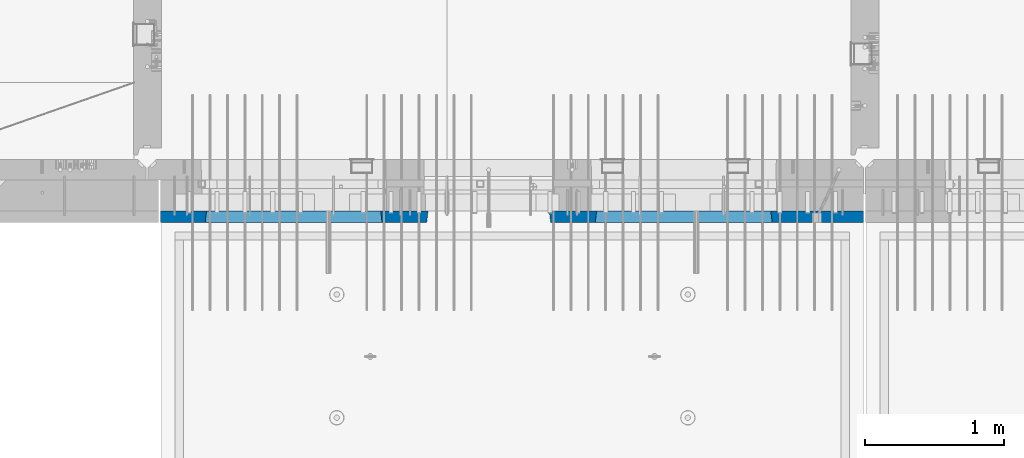
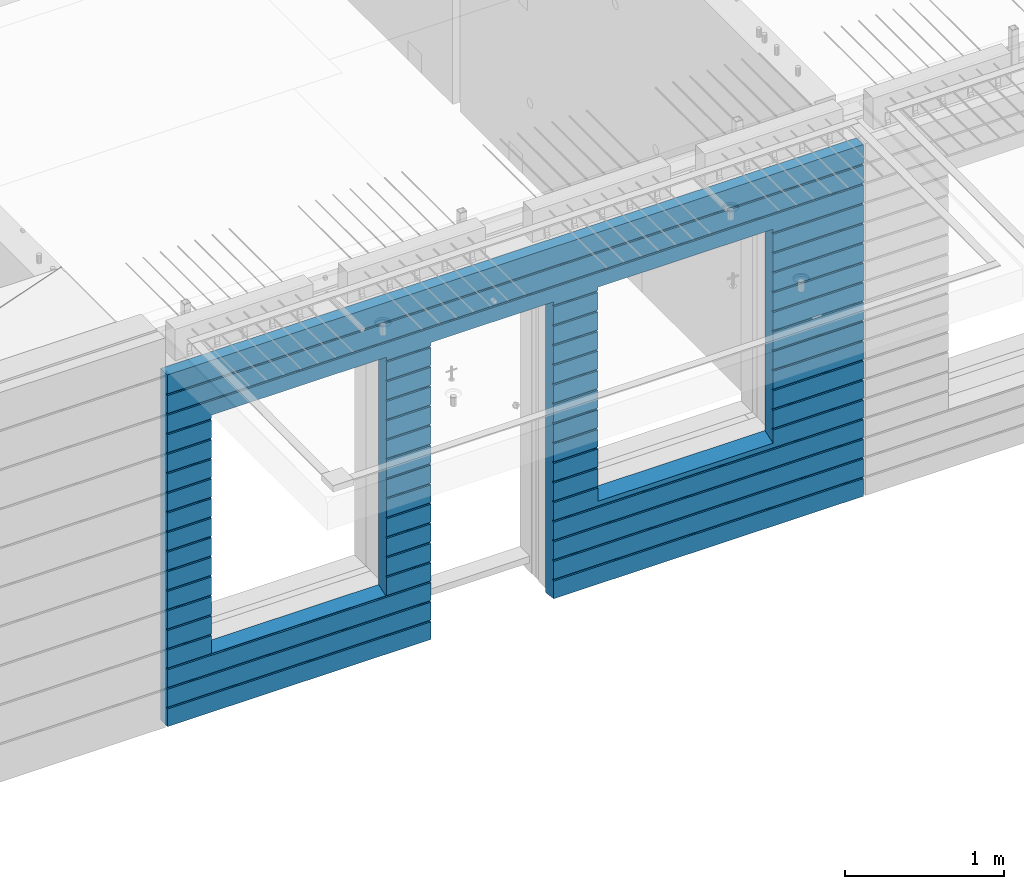
# One storey, part 231 of 352: 1 wall, 1 element without a shape of its own.
"""IFC2X3 building model written with IfcOpenShell, lengths in millimetres."""

from ifc_helpers import new_model, si_unit, frame, origin_with_axes, place, context, subcontext, project, spatial, faceted_brep, material, type_object, element, aggregate, save


model = new_model("IFC2X3")

# Units and contexts
model_context = context("Model", 3, precision=1e-05, world=origin_with_axes())
body_context = subcontext(model_context, "Body", "Model", "MODEL_VIEW")
ifc_project = project(units=[si_unit("LENGTHUNIT", "METRE", prefix="MILLI"), si_unit("AREAUNIT", "SQUARE_METRE"), si_unit("VOLUMEUNIT", "CUBIC_METRE"), si_unit("MASSUNIT", "GRAM", prefix="KILO"), si_unit("TIMEUNIT", "SECOND"), si_unit("PLANEANGLEUNIT", "RADIAN"), si_unit("SOLIDANGLEUNIT", "STERADIAN"), si_unit("THERMODYNAMICTEMPERATUREUNIT", "DEGREE_CELSIUS"), si_unit("LUMINOUSINTENSITYUNIT", "LUMEN")], contexts=[model_context])

# Site, building, storey
site_placement = place(None, origin_with_axes())
site = spatial("IfcSite", under=ifc_project, at=site_placement, CompositionType="ELEMENT")
building_placement = place(site_placement, origin_with_axes())
building = spatial("IfcBuilding", under=site, at=building_placement, CompositionType="ELEMENT")
storey_placement = place(building_placement, origin_with_axes())
storey = spatial("IfcBuildingStorey", under=building, at=storey_placement, Name="6", CompositionType="ELEMENT", Elevation=0.0)

# Assembly, wall
assembly_placement = place(storey_placement, origin_with_axes())
assembly = element("IfcElementAssembly", 1, at=assembly_placement, inside=storey, AssemblyPlace="NOTDEFINED", PredefinedType="REINFORCEMENT_UNIT")
ifc_material = material(Name="CONCRETE/C30/37")
wall_type = type_object("IfcWallType", PredefinedType="NOTDEFINED")
wall_placement = place(assembly_placement, frame((21810.0, 7587.5, 98102.5), z_axis=(0.0, 0.0, 1.0), x_axis=(-1.0, 3.00000001838171e-08, 0.0)))
wall = element("IfcWall", 2, at=wall_placement, type_object=wall_type, material=ifc_material, context=body_context, shape_type="Brep", body=[
    faceted_brep([(3465.15088791894, 41.2121213860573, -911.742424344746), (3464.99937278789, 42.5, -912.5), (3464.99937278789, 42.5, -912.000000055254), (4734.84785765683, 41.2121213860573, -911.742424344746), (4734.99937278789, 42.5, -912.5), (4734.99937278789, 42.5, -912.000000055254), (10.0, 42.5, -1347.5), (10.0, 42.5, -1212.00000005524), (2254.99845837354, 42.5, -1212.00000005524), (2254.99845837354, 42.5, -1347.5), (10.0, 32.4999992501662, -1210.00000000079), (2256.17512512844, 32.4999992501662, -1210.00000000079), (10.0000007500639, 32.499999249937, -1200.00000000079), (2256.17512514468, 32.4999991121731, -1199.99999959956), (10.0, 42.5, -1198.00000011075), (2254.99845837354, 42.5, -1198.00000011075), (10.0, 42.5, -1062.00000005522), (2254.99845837354, 42.5, -1062.00000005522), (10.0, 32.4999992506964, -1060.00000000079), (2256.17512512838, 32.4999992506964, -1060.00000000079), (10.0000007500657, 32.499999249937, -1050.00000000079), (2256.17512514461, 32.499999112697, -1049.99999959956), (10.0, 42.5, -1048.00000011074), (2254.99845837354, 42.5, -1048.00000011074), (10.0, 42.5, -912.000000055254), (2254.99845837354, 42.5, -912.000000055254), (10.0, 32.4999992512312, -910.000000000815), (2256.17512512832, 32.4999992512312, -910.000000000815), (10.0000007500657, 32.499999249937, -900.000000000786), (2256.17512514455, 32.4999991132318, -899.99999959959), (10.0, 42.5, -898.000000110769), (2254.99845837354, 42.5, -898.000000110769), (10.0, 42.5, -762.000000055225), (2254.99845837354, 42.5, -762.000000055225), (10.0, 32.4999992517696, -760.000000000771), (2256.17512512825, 32.4999992517696, -760.000000000771), (10.0000007500657, 32.499999249937, -750.000000000786), (2256.17512514449, 32.4999991137747, -749.999999599546), (10.0, 42.5, -748.00000011074), (2254.99845837354, 42.5, -748.00000011074), (675.00013572734, 42.5, 927.5), (1925.00013572734, 42.5, 927.5), (1935.00013572734, 42.5, 927.5), (1925.00013572734, -42.5, 932.5), (675.00013572734, -42.5, 932.5), (665.00013572734, 42.5, 927.5), (665.00013572734, 42.5, -712.5), (675.00013572734, -42.5, -662.5), (1925.00013572734, -42.5, -662.5), (1935.00013572734, 42.5, -712.5), (1925.00013572734, -42.5, 927.5), (1935.00013572734, 42.5, 901.999999889245), (1933.82366503463, 32.4999991119776, 900.000000400425), (1933.82366505087, 32.4999992499834, 889.9999999992), (1935.00013572734, 42.5, 887.999999944761), (1935.00013572734, 42.5, 751.999999889245), (1933.82366503463, 32.4999991119885, 750.000000400425), (1933.82366505087, 32.4999992499925, 739.9999999992), (1935.00013572734, 42.5, 737.999999944761), (1935.00013572734, 42.5, 601.99999988926), (1933.82366503463, 32.4999991120112, 600.00000040044), (1933.82366505087, 32.4999992500152, 589.999999999214), (1935.00013572734, 42.5, 587.999999944775), (1935.00013572734, 42.5, 451.999999889245), (1933.82366503464, 32.4999991120167, 450.000000400425), (1933.82366505087, 32.4999992500216, 439.9999999992), (1935.00013572734, 42.5, 437.999999944761), (1935.00013572734, 42.5, 301.999999889245), (1933.82366503464, 32.4999991120312, 300.000000400425), (1933.82366505087, 32.4999992500352, 289.9999999992), (1935.00013572734, 42.5, 287.999999944761), (1935.00013572734, 42.5, 151.999999889245), (1933.82366503464, 32.4999991120421, 150.000000400425), (1933.82366505088, 32.499999250047, 139.9999999992), (1935.00013572734, 42.5, 137.999999944761), (1935.00013572734, 42.5, 1.99999988923082), (1933.82366503515, 32.4999991164286, 4.00410499423742e-07), (1933.82366505139, 32.4999992544263, -10.0000000008149), (1935.00013572734, 42.5, -12.0000000552536), (1935.00013572734, 42.5, -148.000000110755), (1933.82366503509, 32.4999991158993, -149.99999959956), (1933.82366505132, 32.4999992538915, -160.000000000786), (1935.00013572734, 42.5, -162.000000055239), (1935.00013572734, 42.5, -298.000000110755), (1933.82366503503, 32.49999911536, -299.999999599575), (1933.82366505126, 32.4999992533594, -310.0000000008), (1935.00013572734, 42.5, -312.000000055239), (1935.00013572734, 42.5, -448.00000011074), (1933.82366503496, 32.4999991148343, -449.99999959956), (1933.8236650512, 32.4999992528337, -460.000000000786), (1935.00013572734, 42.5, -462.000000055225), (1935.00013572734, 42.5, -598.000000110755), (1933.8236650349, 32.499999114295, -599.999999599575), (1933.82366505114, 32.4999992522935, -610.0000000008), (1935.00013572734, 42.5, -612.000000055239), (2256.1751251447, 32.4999991119776, 900.000000400425), (2256.17512512846, 32.4999992499834, 889.9999999992), (2254.99845837354, 42.5, 887.999999944761), (2254.99845837354, 42.5, 751.999999889245), (2256.17512514469, 32.4999991119885, 750.000000400425), (2256.17512512846, 32.4999992499925, 739.9999999992), (2254.99845837354, 42.5, 737.999999944761), (2254.99845837354, 42.5, 601.99999988926), (2256.17512514469, 32.4999991120112, 600.00000040044), (2256.17512512846, 32.4999992500152, 589.999999999214), (2254.99845837354, 42.5, 587.999999944775), (2254.99845837354, 42.5, 451.999999889245), (2256.17512514469, 32.4999991120167, 450.000000400425), (2256.17512512846, 32.4999992500216, 439.9999999992), (2254.99845837354, 42.5, 437.999999944761), (2254.99845837354, 42.5, 301.999999889245), (2256.17512514469, 32.4999991120312, 300.000000400425), (2256.17512512846, 32.4999992500352, 289.9999999992), (2254.99845837354, 42.5, 287.999999944761), (2254.99845837354, 42.5, 151.999999889245), (2256.17512514469, 32.4999991120421, 150.000000400425), (2256.17512512846, 32.499999250047, 139.9999999992), (2254.99845837354, 42.5, 137.999999944761), (2254.99845837354, 42.5, 1.99999988923082), (2256.17512514417, 32.4999991164286, 4.00410499423742e-07), (2256.17512512794, 32.4999992544263, -10.0000000008149), (2254.99845837354, 42.5, -12.0000000552536), (2254.99845837354, 42.5, -148.000000110755), (2256.17512514424, 32.4999991158993, -149.99999959956), (2256.175125128, 32.4999992538915, -160.000000000786), (2254.99845837354, 42.5, -162.000000055239), (2254.99845837354, 42.5, -298.000000110755), (2256.1751251443, 32.49999911536, -299.999999599575), (2256.17512512806, 32.4999992533594, -310.0000000008), (2254.99845837354, 42.5, -312.000000055239), (2254.99845837354, 42.5, -448.00000011074), (2256.17512514436, 32.4999991148343, -449.99999959956), (2256.17512512813, 32.4999992528337, -460.000000000786), (2254.99845837354, 42.5, -462.000000055225), (2254.99845837354, 42.5, -598.000000110755), (2256.17512514443, 32.499999114295, -599.999999599575), (2256.17512512819, 32.4999992522935, -610.0000000008), (2254.99845837354, 42.5, -612.000000055239), (10.0, 42.5, -612.000000055239), (665.00013572734, 42.5, -612.000000055239), (10.0, 32.4999992522935, -610.0000000008), (666.176606403544, 32.4999992522935, -610.0000000008), (10.0000007500657, 32.499999249937, -600.000000000786), (666.176606419776, 32.499999114295, -599.999999599575), (10.0, 42.5, -598.000000110755), (665.00013572734, 42.5, -598.000000110755), (10.0, 42.5, -462.000000055225), (665.00013572734, 42.5, -462.000000055225), (10.0, 32.4999992528337, -460.000000000786), (666.176606403482, 32.4999992528337, -460.000000000786), (10.0000007500657, 32.499999249937, -450.000000000786), (666.176606419715, 32.4999991148343, -449.99999959956), (10.0, 42.5, -448.00000011074), (665.00013572734, 42.5, -448.00000011074), (10.0, 42.5, -312.000000055239), (665.00013572734, 42.5, -312.000000055239), (10.0, 32.4999992533594, -310.0000000008), (666.17660640342, 32.4999992533594, -310.0000000008), (10.0000007500657, 32.499999249937, -300.000000000786), (666.176606419653, 32.49999911536, -299.999999599575), (10.0, 42.5, -298.000000110755), (665.00013572734, 42.5, -298.000000110755), (10.0, 42.5, -162.000000055239), (665.00013572734, 42.5, -162.000000055239), (10.0, 32.4999992538915, -160.000000000786), (666.176606403355, 32.4999992538915, -160.000000000786), (10.0000007500657, 32.499999249937, -150.000000000786), (666.176606419591, 32.4999991158993, -149.99999959956), (10.0, 42.5, -148.000000110755), (665.00013572734, 42.5, -148.000000110755), (10.0, 42.5, -12.0000000552536), (665.00013572734, 42.5, -12.0000000552536), (10.0, 32.4999992544263, -10.0000000008149), (666.176606403293, 32.4999992544263, -10.0000000008149), (10.0000007500657, 32.499999249937, -7.8580342233181e-10), (666.176606419529, 32.4999991164286, 4.00410499423742e-07), (10.0, 42.5, 1.99999988923082), (665.00013572734, 42.5, 1.99999988923082), (10.0, 42.5, 137.999999944761), (665.00013572734, 42.5, 137.999999944761), (10.0, 32.499999250047, 139.9999999992), (666.176606403806, 32.499999250047, 139.9999999992), (10.0000007500657, 32.499999249937, 149.999999999214), (666.176606420046, 32.4999991120421, 150.000000400425), (10.0, 42.5, 151.999999889245), (665.00013572734, 42.5, 151.999999889245), (10.0, 42.5, 287.999999944761), (665.00013572734, 42.5, 287.999999944761), (10.0, 32.4999992500352, 289.9999999992), (666.176606403809, 32.4999992500352, 289.9999999992), (10.0000007500657, 32.499999249937, 299.999999999214), (666.176606420046, 32.4999991120312, 300.000000400425), (10.0, 42.5, 301.999999889245), (665.00013572734, 42.5, 301.999999889245), (10.0, 42.5, 437.999999944761), (665.00013572734, 42.5, 437.999999944761), (10.0, 32.4999992500216, 439.9999999992), (666.176606403809, 32.4999992500216, 439.9999999992), (10.0000007500657, 32.499999249937, 449.999999999214), (666.176606420046, 32.4999991120167, 450.000000400425), (10.0, 42.5, 451.999999889245), (665.00013572734, 42.5, 451.999999889245), (10.0, 42.5, 587.999999944775), (665.00013572734, 42.5, 587.999999944775), (10.0, 32.4999992500152, 589.999999999214), (666.176606403809, 32.4999992500152, 589.999999999214), (10.0000007500657, 32.499999249937, 599.999999999214), (666.176606420049, 32.4999991120112, 600.00000040044), (10.0, 42.5, 601.99999988926), (665.00013572734, 42.5, 601.99999988926), (10.0, 42.5, 737.999999944761), (665.00013572734, 42.5, 737.999999944761), (9.99999999999636, 32.4999992499925, 739.9999999992), (666.176606403813, 32.4999992499925, 739.9999999992), (10.0000007500657, 32.499999249937, 749.999999999214), (666.176606420049, 32.4999991119885, 750.000000400425), (10.0, 42.5, 751.999999889245), (665.00013572734, 42.5, 751.999999889245), (10.0, 42.5, 887.999999944761), (665.00013572734, 42.5, 887.999999944761), (10.0, 32.4999992499834, 889.9999999992), (666.176606403813, 32.4999992499834, 889.9999999992), (10.0000007500657, 32.499999249937, 899.999999999214), (666.176606420053, 32.4999991119776, 900.000000400425), (675.00013572734, -42.5, 927.5), (665.00013572734, 42.5, 901.999999889245), (10.0, 42.5, 901.999999889245), (10.0, 42.5, 1051.99999988925), (5055.0, 42.5, 1051.99999988925), (5055.0, 32.4999991119666, 1050.00000040043), (10.0000007500657, 32.499999249937, 1049.99999999921), (5055.0, 32.4999992499706, 1039.9999999992), (10.0, 32.4999992499706, 1039.9999999992), (5055.0, 42.5, 1037.99999994476), (10.0, 42.5, 1037.99999994476), (5055.0, 42.5, 901.999999889245), (5055.0, 32.4999991119776, 900.000000400425), (4733.82290209518, 32.4999991119776, 900.000000400425), (4734.99937278789, 42.5, 901.999999889245), (5055.0, 32.4999992499834, 889.9999999992), (4733.82290211141, 32.4999992499834, 889.9999999992), (5055.0, 42.5, 887.999999944761), (4734.99937278789, 42.5, 887.999999944761), (5055.0, 42.5, 751.999999889245), (4734.99937278789, 42.5, 751.999999889245), (5055.0, 32.4999991119885, 750.000000400425), (4733.82290209518, 32.4999991119885, 750.000000400425), (5055.0, 32.4999992499925, 739.9999999992), (4733.82290211142, 32.4999992499925, 739.9999999992), (5055.0, 42.5, 737.999999944761), (4734.99937278789, 42.5, 737.999999944761), (5055.0, 42.5, 601.99999988926), (4734.99937278789, 42.5, 601.99999988926), (5055.0, 32.4999991120112, 600.00000040044), (4733.82290209518, 32.4999991120112, 600.00000040044), (5055.0, 32.4999992500152, 589.999999999214), (4733.82290211142, 32.4999992500152, 589.999999999214), (5055.0, 42.5, 587.999999944775), (4734.99937278789, 42.5, 587.999999944775), (5055.0, 42.5, 451.999999889245), (4734.99937278789, 42.5, 451.999999889245), (5055.0, 32.4999991120167, 450.000000400425), (4733.82290209518, 32.4999991120167, 450.000000400425), (5055.0, 32.4999992500216, 439.9999999992), (4733.82290211142, 32.4999992500216, 439.9999999992), (5055.0, 42.5, 437.999999944761), (4734.99937278789, 42.5, 437.999999944761), (5055.0, 42.5, 301.999999889245), (4734.99937278789, 42.5, 301.999999889245), (5055.0, 32.4999991120312, 300.000000400425), (4733.82290209518, 32.4999991120312, 300.000000400425), (5055.0, 32.4999992500352, 289.9999999992), (4733.82290211142, 32.4999992500352, 289.9999999992), (5055.0, 42.5, 287.999999944761), (4734.99937278789, 42.5, 287.999999944761), (5055.0, 42.5, 151.999999889245), (4734.99937278789, 42.5, 151.999999889245), (5055.0, 32.4999991120421, 150.000000400425), (4733.82290209519, 32.4999991120421, 150.000000400425), (5055.0, 32.499999250047, 139.9999999992), (4733.82290211142, 32.499999250047, 139.9999999992), (5055.0, 42.5, 137.999999944761), (4734.99937278789, 42.5, 137.999999944761), (5055.0, 42.5, 1.99999988923082), (4734.99937278789, 42.5, 1.99999988923082), (5055.0, 32.4999991164286, 4.00410499423742e-07), (4733.8229020957, 32.4999991164286, 4.00410499423742e-07), (5055.0, 32.4999992544263, -10.0000000008149), (4733.82290211194, 32.4999992544263, -10.0000000008149), (5055.0, 42.5, -12.0000000552536), (4734.99937278789, 42.5, -12.0000000552536), (5055.0, 42.5, -148.000000110755), (4734.99937278789, 42.5, -148.000000110755), (5055.0, 32.4999991158993, -149.99999959956), (4733.82290209564, 32.4999991158993, -149.99999959956), (5055.0, 32.4999992538915, -160.000000000786), (4733.82290211188, 32.4999992538915, -160.000000000786), (5055.0, 42.5, -162.000000055239), (4734.99937278789, 42.5, -162.000000055239), (5055.0, 42.5, -298.000000110755), (4734.99937278789, 42.5, -298.000000110755), (5055.0, 32.49999911536, -299.999999599575), (4733.82290209558, 32.49999911536, -299.999999599575), (5055.0, 32.4999992533594, -310.0000000008), (4733.82290211181, 32.4999992533594, -310.0000000008), (5055.0, 42.5, -312.000000055239), (4734.99937278789, 42.5, -312.000000055239), (5055.0, 42.5, -448.00000011074), (4734.99937278789, 42.5, -448.00000011074), (5055.0, 32.4999991148343, -449.99999959956), (4733.82290209552, 32.4999991148343, -449.99999959956), (5055.0, 32.4999992528337, -460.000000000786), (4733.82290211175, 32.4999992528337, -460.000000000786), (5055.0, 42.5, -462.000000055225), (4734.99937278789, 42.5, -462.000000055225), (5055.0, 42.5, -598.000000110755), (4734.99937278789, 42.5, -598.000000110755), (5055.0, 32.499999114295, -599.999999599575), (4733.82290209545, 32.499999114295, -599.999999599575), (5055.0, 32.4999992522935, -610.0000000008), (4733.82290211169, 32.4999992522935, -610.0000000008), (5055.0, 42.5, -612.000000055239), (4734.99937278789, 42.5, -612.000000055239), (5055.0, 42.5, -748.00000011074), (4734.99937278789, 42.5, -748.00000011074), (5055.0, 32.4999991137747, -749.999999599546), (4733.82290209539, 32.4999991137747, -749.999999599546), (5055.0, 32.4999992517696, -760.000000000771), (4733.82290211162, 32.4999992517696, -760.000000000771), (5055.0, 42.5, -762.000000055225), (4734.99937278789, 42.5, -762.000000055225), (5055.0, 42.5, -898.000000110769), (4734.99937278789, 42.5, -898.000000110769), (5055.0, 32.4999991132318, -899.99999959959), (4733.82290209533, 32.4999991132318, -899.99999959959), (3466.1758434697, 32.499999204555, -906.617646590923), (3474.99937278789, -42.5, -862.5), (4724.99937278789, -42.5, -862.5), (4733.82290210607, 32.499999204555, -906.617646590923), (4724.99937278789, -42.5, 927.5), (4724.99937278789, -42.5, 932.5), (4734.99937278789, 42.5, 927.5), (2265.00051719707, 42.5, 927.5), (3135.00051719707, 42.5, 927.5), (3144.99845837354, 42.5, 927.5), (3134.99679170688, -42.5, 932.502857142856), (2265.00012504021, -42.5, 932.502857142856), (2254.99845837354, 42.5, 927.5), (4724.99937278789, 42.5, 927.5), (3474.99937278789, 42.5, 927.5), (3464.99937278789, 42.5, 927.5), (3464.99937278789, 42.5, 901.999999889245), (3144.99845837354, 42.5, 901.999999889245), (2254.99845837354, 42.5, 901.999999889245), (2265.00012504021, -42.5, 927.5), (2265.00012504021, -42.5, -1347.5), (10.0, -42.5, -1347.5), (10.0, 42.5, 1347.5), (10.0, -42.5, 1347.5), (5055.0, -42.5, 1347.5), (5055.0, 42.5, 1347.5), (5055.0, 42.5, 1201.99999988925), (10.0, 42.5, 1201.99999988925), (10.0, 42.5, 1187.99999994476), (10.0000007500657, 32.499999249937, 1199.99999999921), (9.99999999999636, 32.4999992499606, 1189.9999999992), (5055.0, 42.5, 1187.99999994476), (5055.0, 32.4999992499606, 1189.9999999992), (5055.0, 32.4999991119566, 1200.00000040043), (5055.0, -42.5, -1347.5), (5055.0, 42.5, -1347.5), (5055.0, 42.5, -1212.00000005524), (5055.0, 32.4999992501662, -1210.00000000079), (5055.0, 32.4999991121731, -1199.99999959956), (5055.0, 42.5, -1198.00000011075), (5055.0, 42.5, -1062.00000005522), (5055.0, 32.4999992506964, -1060.00000000079), (5055.0, 32.499999112697, -1049.99999959956), (5055.0, 42.5, -1048.00000011074), (5055.0, 42.5, -912.000000055254), (5055.0, 32.4999992512312, -910.000000000815), (3144.99845837354, 42.5, -1212.00000005524), (3143.82179161865, 32.4999992501662, -1210.00000000079), (3143.82179160241, 32.4999991121731, -1199.99999959956), (3144.99845837354, 42.5, -1198.00000011075), (3144.99845837354, 42.5, -1062.00000005522), (3143.82179161871, 32.4999992506964, -1060.00000000079), (3143.82179160247, 32.499999112697, -1049.99999959956), (3144.99845837354, 42.5, -1048.00000011074), (3144.99845837354, 42.5, -912.000000055254), (3143.82179161877, 32.4999992512312, -910.000000000815), (3466.17584348045, 32.4999991132318, -899.99999959959), (3143.82179160253, 32.4999991132318, -899.99999959959), (3464.99937278789, 42.5, -898.000000110769), (3144.99845837354, 42.5, -898.000000110769), (3464.99937278789, 42.5, -762.000000055225), (3144.99845837354, 42.5, -762.000000055225), (3466.17584346415, 32.4999992517696, -760.000000000771), (3143.82179161884, 32.4999992517696, -760.000000000771), (3466.17584348039, 32.4999991137747, -749.999999599546), (3143.8217916026, 32.4999991137747, -749.999999599546), (3464.99937278789, 42.5, -748.00000011074), (3144.99845837354, 42.5, -748.00000011074), (3464.99937278789, 42.5, -612.000000055239), (3144.99845837354, 42.5, -612.000000055239), (3466.17584346409, 32.4999992522935, -610.0000000008), (3143.8217916189, 32.4999992522935, -610.0000000008), (3466.17584348032, 32.499999114295, -599.999999599575), (3143.82179160266, 32.499999114295, -599.999999599575), (3464.99937278789, 42.5, -598.000000110755), (3144.99845837354, 42.5, -598.000000110755), (3464.99937278789, 42.5, -462.000000055225), (3144.99845837354, 42.5, -462.000000055225), (3466.17584346403, 32.4999992528337, -460.000000000786), (3143.82179161896, 32.4999992528337, -460.000000000786), (3466.17584348026, 32.4999991148343, -449.99999959956), (3143.82179160272, 32.4999991148343, -449.99999959956), (3464.99937278789, 42.5, -448.00000011074), (3144.99845837354, 42.5, -448.00000011074), (3464.99937278789, 42.5, -312.000000055239), (3144.99845837354, 42.5, -312.000000055239), (3466.17584346396, 32.4999992533594, -310.0000000008), (3143.82179161902, 32.4999992533594, -310.0000000008), (3466.1758434802, 32.49999911536, -299.999999599575), (3143.82179160278, 32.49999911536, -299.999999599575), (3464.99937278789, 42.5, -298.000000110755), (3144.99845837354, 42.5, -298.000000110755), (3464.99937278789, 42.5, -162.000000055239), (3144.99845837354, 42.5, -162.000000055239), (3466.1758434639, 32.4999992538915, -160.000000000786), (3143.82179161909, 32.4999992538915, -160.000000000786), (3466.17584348014, 32.4999991158993, -149.99999959956), (3143.82179160284, 32.4999991158993, -149.99999959956), (3464.99937278789, 42.5, -148.000000110755), (3144.99845837354, 42.5, -148.000000110755), (3464.99937278789, 42.5, -12.0000000552536), (3144.99845837354, 42.5, -12.0000000552536), (3466.17584346384, 32.4999992544263, -10.0000000008149), (3143.82179161915, 32.4999992544263, -10.0000000008149), (3466.17584348008, 32.4999991164286, 4.00410499423742e-07), (3143.82179160291, 32.4999991164286, 4.00410499423742e-07), (3464.99937278789, 42.5, 1.99999988923082), (3144.99845837354, 42.5, 1.99999988923082), (3464.99937278789, 42.5, 137.999999944761), (3144.99845837354, 42.5, 137.999999944761), (3466.17584346435, 32.499999250047, 139.9999999992), (3143.82179161863, 32.499999250047, 139.9999999992), (3466.17584348059, 32.4999991120421, 150.000000400425), (3143.82179160239, 32.4999991120421, 150.000000400425), (3464.99937278789, 42.5, 151.999999889245), (3144.99845837354, 42.5, 151.999999889245), (3464.99937278789, 42.5, 287.999999944761), (3144.99845837354, 42.5, 287.999999944761), (3466.17584346436, 32.4999992500352, 289.9999999992), (3143.82179161863, 32.4999992500352, 289.9999999992), (3466.17584348059, 32.4999991120312, 300.000000400425), (3143.82179160239, 32.4999991120312, 300.000000400425), (3464.99937278789, 42.5, 301.999999889245), (3144.99845837354, 42.5, 301.999999889245), (3464.99937278789, 42.5, 437.999999944761), (3144.99845837354, 42.5, 437.999999944761), (3466.17584346436, 32.4999992500216, 439.9999999992), (3143.82179161863, 32.4999992500216, 439.9999999992), (3466.17584348059, 32.4999991120167, 450.000000400425), (3143.82179160239, 32.4999991120167, 450.000000400425), (3464.99937278789, 42.5, 451.999999889245), (3144.99845837354, 42.5, 451.999999889245), (3464.99937278789, 42.5, 587.999999944775), (3144.99845837354, 42.5, 587.999999944775), (3466.17584346436, 32.4999992500152, 589.999999999214), (3143.82179161863, 32.4999992500152, 589.999999999214), (3466.1758434806, 32.4999991120112, 600.00000040044), (3143.82179160239, 32.4999991120112, 600.00000040044), (3464.99937278789, 42.5, 601.99999988926), (3144.99845837354, 42.5, 601.99999988926), (3464.99937278789, 42.5, 737.999999944761), (3144.99845837354, 42.5, 737.999999944761), (3466.17584346436, 32.4999992499925, 739.9999999992), (3143.82179161863, 32.4999992499925, 739.9999999992), (3466.1758434806, 32.4999991119885, 750.000000400425), (3143.82179160239, 32.4999991119885, 750.000000400425), (3464.99937278789, 42.5, 751.999999889245), (3144.99845837354, 42.5, 751.999999889245), (3464.99937278789, 42.5, 887.999999944761), (3144.99845837354, 42.5, 887.999999944761), (3466.17584346436, 32.4999992499834, 889.9999999992), (3143.82179161863, 32.4999992499834, 889.9999999992), (3466.1758434806, 32.4999991119776, 900.000000400425), (3143.82179160239, 32.4999991119776, 900.000000400425), (3474.99937278789, -42.5, 932.5), (3474.99937278789, -42.5, 927.5), (3134.99679170688, -42.5, 927.5), (3134.99679170688, -42.5, -1347.5), (3144.99845837354, 42.5, -1347.5)], [[[0, 1, 2]], [[3, 4, 1, 0]], [[5, 4, 3]], [[6, 7, 8, 9]], [[7, 10, 11, 8]], [[10, 12, 13, 11]], [[12, 14, 15, 13]], [[14, 16, 17, 15]], [[16, 18, 19, 17]], [[18, 20, 21, 19]], [[20, 22, 23, 21]], [[22, 24, 25, 23]], [[24, 26, 27, 25]], [[26, 28, 29, 27]], [[28, 30, 31, 29]], [[30, 32, 33, 31]], [[32, 34, 35, 33]], [[34, 36, 37, 35]], [[36, 38, 39, 37]], [[40, 41, 42, 43, 44, 45]], [[46, 47, 48, 49]], [[50, 43, 42, 51, 52, 53, 54, 55, 56, 57, 58, 59, 60, 61, 62, 63, 64, 65, 66, 67, 68, 69, 70, 71, 72, 73, 74, 75, 76, 77, 78, 79, 80, 81, 82, 83, 84, 85, 86, 87, 88, 89, 90, 91, 92, 93, 94, 49, 48]], [[53, 52, 95, 96]], [[54, 53, 96, 97]], [[55, 54, 97, 98]], [[56, 55, 98, 99]], [[57, 56, 99, 100]], [[58, 57, 100, 101]], [[59, 58, 101, 102]], [[60, 59, 102, 103]], [[61, 60, 103, 104]], [[62, 61, 104, 105]], [[63, 62, 105, 106]], [[64, 63, 106, 107]], [[65, 64, 107, 108]], [[66, 65, 108, 109]], [[67, 66, 109, 110]], [[68, 67, 110, 111]], [[69, 68, 111, 112]], [[70, 69, 112, 113]], [[71, 70, 113, 114]], [[72, 71, 114, 115]], [[73, 72, 115, 116]], [[74, 73, 116, 117]], [[75, 74, 117, 118]], [[76, 75, 118, 119]], [[77, 76, 119, 120]], [[78, 77, 120, 121]], [[79, 78, 121, 122]], [[80, 79, 122, 123]], [[81, 80, 123, 124]], [[82, 81, 124, 125]], [[83, 82, 125, 126]], [[84, 83, 126, 127]], [[85, 84, 127, 128]], [[86, 85, 128, 129]], [[87, 86, 129, 130]], [[88, 87, 130, 131]], [[89, 88, 131, 132]], [[90, 89, 132, 133]], [[91, 90, 133, 134]], [[92, 91, 134, 135]], [[93, 92, 135, 136]], [[94, 93, 136, 137]], [[38, 138, 139, 46, 49, 94, 137, 39]], [[138, 140, 141, 139]], [[140, 142, 143, 141]], [[142, 144, 145, 143]], [[144, 146, 147, 145]], [[146, 148, 149, 147]], [[148, 150, 151, 149]], [[150, 152, 153, 151]], [[152, 154, 155, 153]], [[154, 156, 157, 155]], [[156, 158, 159, 157]], [[158, 160, 161, 159]], [[160, 162, 163, 161]], [[162, 164, 165, 163]], [[164, 166, 167, 165]], [[166, 168, 169, 167]], [[168, 170, 171, 169]], [[170, 172, 173, 171]], [[172, 174, 175, 173]], [[174, 176, 177, 175]], [[176, 178, 179, 177]], [[178, 180, 181, 179]], [[180, 182, 183, 181]], [[182, 184, 185, 183]], [[184, 186, 187, 185]], [[186, 188, 189, 187]], [[188, 190, 191, 189]], [[190, 192, 193, 191]], [[192, 194, 195, 193]], [[194, 196, 197, 195]], [[196, 198, 199, 197]], [[198, 200, 201, 199]], [[200, 202, 203, 201]], [[202, 204, 205, 203]], [[204, 206, 207, 205]], [[206, 208, 209, 207]], [[208, 210, 211, 209]], [[210, 212, 213, 211]], [[212, 214, 215, 213]], [[214, 216, 217, 215]], [[216, 218, 219, 217]], [[218, 220, 221, 219]], [[220, 222, 223, 221]], [[45, 44, 224, 47, 46, 139, 141, 143, 145, 147, 149, 151, 153, 155, 157, 159, 161, 163, 165, 167, 169, 171, 173, 175, 177, 179, 181, 183, 185, 187, 189, 191, 193, 195, 197, 199, 201, 203, 205, 207, 209, 211, 213, 215, 217, 219, 221, 223, 225]], [[222, 226, 225, 223]], [[227, 228, 229, 230]], [[230, 229, 231, 232]], [[232, 231, 233, 234]], [[235, 236, 237, 238]], [[236, 239, 240, 237]], [[239, 241, 242, 240]], [[241, 243, 244, 242]], [[243, 245, 246, 244]], [[245, 247, 248, 246]], [[247, 249, 250, 248]], [[249, 251, 252, 250]], [[251, 253, 254, 252]], [[253, 255, 256, 254]], [[255, 257, 258, 256]], [[257, 259, 260, 258]], [[259, 261, 262, 260]], [[261, 263, 264, 262]], [[263, 265, 266, 264]], [[265, 267, 268, 266]], [[267, 269, 270, 268]], [[269, 271, 272, 270]], [[271, 273, 274, 272]], [[273, 275, 276, 274]], [[275, 277, 278, 276]], [[277, 279, 280, 278]], [[279, 281, 282, 280]], [[281, 283, 284, 282]], [[283, 285, 286, 284]], [[285, 287, 288, 286]], [[287, 289, 290, 288]], [[289, 291, 292, 290]], [[291, 293, 294, 292]], [[293, 295, 296, 294]], [[295, 297, 298, 296]], [[297, 299, 300, 298]], [[299, 301, 302, 300]], [[301, 303, 304, 302]], [[303, 305, 306, 304]], [[305, 307, 308, 306]], [[307, 309, 310, 308]], [[309, 311, 312, 310]], [[311, 313, 314, 312]], [[313, 315, 316, 314]], [[315, 317, 318, 316]], [[317, 319, 320, 318]], [[319, 321, 322, 320]], [[321, 323, 324, 322]], [[323, 325, 326, 324]], [[325, 327, 328, 326]], [[327, 329, 330, 328]], [[329, 331, 332, 330]], [[331, 333, 334, 332]], [[335, 336, 337, 338]], [[339, 340, 341, 238, 237, 240, 242, 244, 246, 248, 250, 252, 254, 256, 258, 260, 262, 264, 266, 268, 270, 272, 274, 276, 278, 280, 282, 284, 286, 288, 290, 292, 294, 296, 298, 300, 302, 304, 306, 308, 310, 312, 314, 316, 318, 320, 322, 324, 326, 328, 330, 332, 334, 338, 337]], [[342, 343, 344, 345, 346, 347]], [[51, 42, 41, 40, 45, 225, 226, 234, 233, 235, 238, 341, 348, 349, 350, 351, 352, 344, 343, 342, 347, 353]], [[52, 51, 353, 95]], [[347, 346, 354, 355, 9, 8, 11, 13, 15, 17, 19, 21, 23, 25, 27, 29, 31, 33, 35, 37, 39, 137, 136, 135, 134, 133, 132, 131, 130, 129, 128, 127, 126, 125, 124, 123, 122, 121, 120, 119, 118, 117, 116, 115, 114, 113, 112, 111, 110, 109, 108, 107, 106, 105, 104, 103, 102, 101, 100, 99, 98, 97, 96, 95, 353]], [[356, 6, 9, 355]], [[357, 358, 359, 360]], [[357, 360, 361, 362]], [[363, 227, 230, 232, 234, 226, 222, 220, 218, 216, 214, 212, 210, 208, 206, 204, 202, 200, 198, 196, 194, 192, 190, 188, 186, 184, 182, 180, 178, 176, 174, 172, 170, 168, 166, 164, 162, 160, 158, 156, 154, 152, 150, 148, 146, 144, 142, 140, 138, 38, 36, 34, 32, 30, 28, 26, 24, 22, 20, 18, 16, 14, 12, 10, 7, 6, 356, 358, 357, 362, 364, 365]], [[228, 227, 363, 366]], [[365, 367, 366, 363]], [[364, 368, 367, 365]], [[362, 361, 368, 364]], [[360, 359, 369, 370, 371, 372, 373, 374, 375, 376, 377, 378, 379, 380, 333, 331, 329, 327, 325, 323, 321, 319, 317, 315, 313, 311, 309, 307, 305, 303, 301, 299, 297, 295, 293, 291, 289, 287, 285, 283, 281, 279, 277, 275, 273, 271, 269, 267, 265, 263, 261, 259, 257, 255, 253, 251, 249, 247, 245, 243, 241, 239, 236, 235, 233, 231, 229, 228, 366, 367, 368, 361]], [[372, 371, 381, 382]], [[373, 372, 382, 383]], [[374, 373, 383, 384]], [[375, 374, 384, 385]], [[376, 375, 385, 386]], [[377, 376, 386, 387]], [[378, 377, 387, 388]], [[2, 1, 4, 5, 379, 378, 388, 389]], [[380, 379, 5, 3, 0, 2, 389, 390]], [[391, 335, 338, 334, 333, 380, 390, 392]], [[393, 391, 392, 394]], [[395, 393, 394, 396]], [[397, 395, 396, 398]], [[399, 397, 398, 400]], [[401, 399, 400, 402]], [[403, 401, 402, 404]], [[405, 403, 404, 406]], [[407, 405, 406, 408]], [[409, 407, 408, 410]], [[411, 409, 410, 412]], [[413, 411, 412, 414]], [[415, 413, 414, 416]], [[417, 415, 416, 418]], [[419, 417, 418, 420]], [[421, 419, 420, 422]], [[423, 421, 422, 424]], [[425, 423, 424, 426]], [[427, 425, 426, 428]], [[429, 427, 428, 430]], [[431, 429, 430, 432]], [[433, 431, 432, 434]], [[435, 433, 434, 436]], [[437, 435, 436, 438]], [[439, 437, 438, 440]], [[441, 439, 440, 442]], [[443, 441, 442, 444]], [[445, 443, 444, 446]], [[447, 445, 446, 448]], [[449, 447, 448, 450]], [[451, 449, 450, 452]], [[453, 451, 452, 454]], [[455, 453, 454, 456]], [[457, 455, 456, 458]], [[459, 457, 458, 460]], [[461, 459, 460, 462]], [[463, 461, 462, 464]], [[465, 463, 464, 466]], [[467, 465, 466, 468]], [[469, 467, 468, 470]], [[471, 469, 470, 472]], [[473, 471, 472, 474]], [[475, 473, 474, 476]], [[477, 475, 476, 478]], [[479, 477, 478, 480]], [[481, 479, 480, 482]], [[483, 481, 482, 484]], [[485, 483, 484, 486]], [[487, 485, 486, 488]], [[351, 487, 488, 352]], [[350, 489, 490, 336, 335, 391, 393, 395, 397, 399, 401, 403, 405, 407, 409, 411, 413, 415, 417, 419, 421, 423, 425, 427, 429, 431, 433, 435, 437, 439, 441, 443, 445, 447, 449, 451, 453, 455, 457, 459, 461, 463, 465, 467, 469, 471, 473, 475, 477, 479, 481, 483, 485, 487, 351]], [[349, 348, 341, 340, 489, 350]], [[491, 492, 369, 359, 358, 356, 355, 354, 346, 345], [339, 337, 336, 490, 489, 340], [50, 48, 47, 224, 44, 43]], [[370, 369, 492, 493]], [[491, 345, 344, 352, 488, 486, 484, 482, 480, 478, 476, 474, 472, 470, 468, 466, 464, 462, 460, 458, 456, 454, 452, 450, 448, 446, 444, 442, 440, 438, 436, 434, 432, 430, 428, 426, 424, 422, 420, 418, 416, 414, 412, 410, 408, 406, 404, 402, 400, 398, 396, 394, 392, 390, 389, 388, 387, 386, 385, 384, 383, 382, 381, 493, 492]], [[371, 370, 493, 381]]]),
])
aggregate(assembly, [wall])

save(model, "model.ifc")
